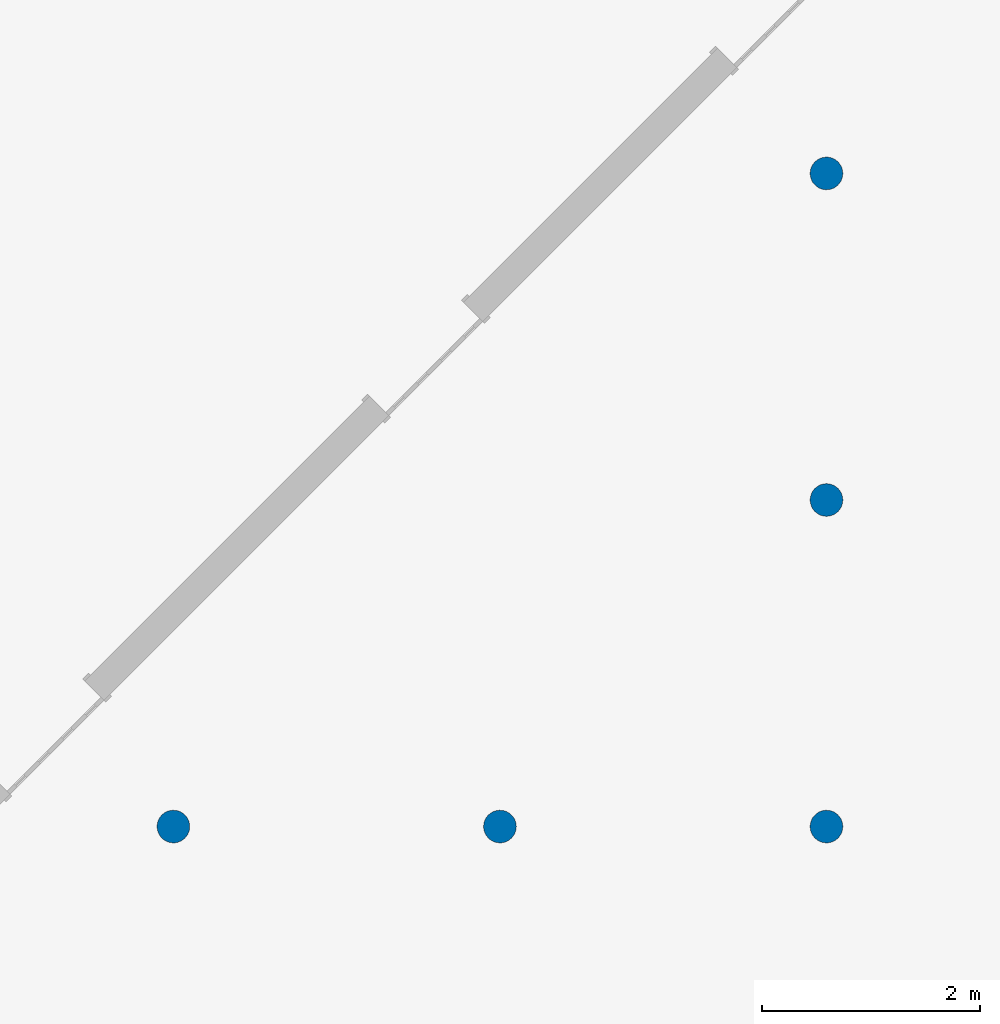
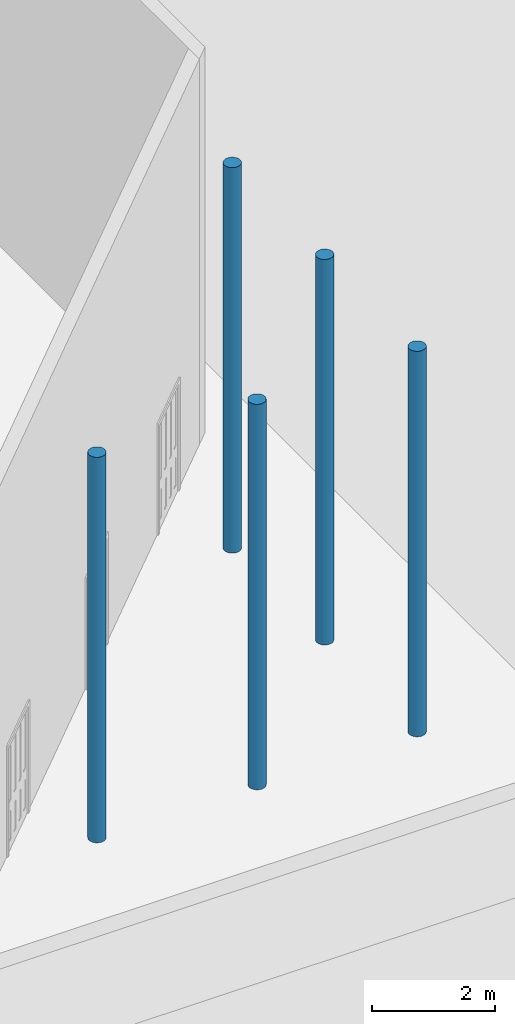
# One storey, part 4 of 39: 5 columns.
"""IFC2X3 building model written with IfcOpenShell, lengths in millimetres."""

from ifc_helpers import new_model, entity, si_unit, converted_unit, derived_unit, direction, frame, frame_2d, origin, place, context, subcontext, project, spatial, circle, extrude, source, transform, mapped, material, type_object, type_shapes, element, save


model = new_model("IFC2X3")

# Units and contexts
model_context = context("Model", 3, precision=1e-06, world=origin(), true_north=direction((2.0, 6.12303176911189e-17, 1.0)))
context_of_model = context(None, 3, precision=1e-06, world=origin(), true_north=direction((2.0, 6.12303176911189e-17, 1.0)))
body_context = subcontext(model_context, "Body", "Model", "MODEL_VIEW")
ifc_project = project(units=[si_unit("LENGTHUNIT", "METRE", prefix="MILLI"), si_unit("AREAUNIT", "SQUARE_METRE", prefix="MILLI"), si_unit("VOLUMEUNIT", "CUBIC_METRE", prefix="MILLI"), converted_unit("PLANEANGLEUNIT", "DEGREE", entity("IfcRatioMeasure", 0.0174532925199433), si_unit("PLANEANGLEUNIT", "RADIAN"), dimensions=[0, 0, 0, 0, 0, 0, 0]), si_unit("MASSUNIT", "GRAM", prefix="KILO"), si_unit("TIMEUNIT", "SECOND"), si_unit("THERMODYNAMICTEMPERATUREUNIT", "KELVIN"), derived_unit("THERMALTRANSMITTANCEUNIT", [(si_unit("MASSUNIT", "GRAM", prefix="KILO"), 1), (si_unit("THERMODYNAMICTEMPERATUREUNIT", "KELVIN"), -1), (si_unit("TIMEUNIT", "SECOND"), -3)]), derived_unit("VOLUMETRICFLOWRATEUNIT", [(si_unit("LENGTHUNIT", "METRE"), 3), (si_unit("TIMEUNIT", "SECOND"), -1)])], contexts=[model_context, context_of_model])

# Site, building, storey
site_placement = place(None, origin())
site = spatial("IfcSite", under=ifc_project, at=site_placement, CompositionType="ELEMENT")
building_placement = place(site_placement, origin())
building = spatial("IfcBuilding", under=site, at=building_placement, CompositionType="ELEMENT")
storey_placement = place(building_placement, frame((0.0, 0.0, 4000.0)))
storey = spatial("IfcBuildingStorey", under=building, at=storey_placement, Name="Level 2", CompositionType="ELEMENT", Elevation=4000.0)

# Columns
ifc_material = material(Name="Concrete - Cast-in-Place Concrete")
column_type_1 = type_object("IfcColumnType", Name="300mm", PredefinedType="COLUMN", material=ifc_material)
shared_shape_1 = source(origin(), body_context, "Body", "SweptSolid", [
    extrude(circle(Radius=149.999999999996, at=frame_2d((-49879.5139476853, 706004.002622383), x_axis=(1.0, 0.0))), origin(), (0.0, 0.0, 1.0), 7638.0),
])
type_shapes(column_type_1, [shared_shape_1])
column_1_placement = place(storey_placement, frame((0.0, 0.0, 362.0)))
element("IfcColumn", 1, at=column_1_placement, inside=storey, type_object=column_type_1, material=ifc_material, Name="M_Concrete-Round-Column:300mm", ObjectType="300mm", context=body_context, shape_type="MappedRepresentation", body=[
    mapped(shared_shape_1, transform((0.0, 0.0, 0.0), scale=1.0)),
])
column_type_2 = type_object("IfcColumnType", Name="300mm", PredefinedType="COLUMN", material=ifc_material)
shared_shape_2 = source(origin(), body_context, "Body", "SweptSolid", [
    extrude(circle(Radius=149.999999999996, at=frame_2d((-52879.5139476853, 706004.002622383), x_axis=(1.0, 0.0))), origin(), (0.0, 0.0, 1.0), 7638.0),
])
type_shapes(column_type_2, [shared_shape_2])
column_2_placement = place(storey_placement, frame((0.0, 0.0, 362.0)))
element("IfcColumn", 2, at=column_2_placement, inside=storey, type_object=column_type_2, material=ifc_material, Name="M_Concrete-Round-Column:300mm", ObjectType="300mm", context=body_context, shape_type="MappedRepresentation", body=[
    mapped(shared_shape_2, transform((0.0, 0.0, 0.0), scale=1.0)),
])
column_type_3 = type_object("IfcColumnType", Name="300mm", PredefinedType="COLUMN", material=ifc_material)
shared_shape_3 = source(origin(), body_context, "Body", "SweptSolid", [
    extrude(circle(Radius=149.999999999996, at=frame_2d((-55879.5139476853, 706004.002622383), x_axis=(1.0, 0.0))), origin(), (0.0, 0.0, 1.0), 7638.0),
])
type_shapes(column_type_3, [shared_shape_3])
column_3_placement = place(storey_placement, frame((0.0, 0.0, 362.0)))
element("IfcColumn", 3, at=column_3_placement, inside=storey, type_object=column_type_3, material=ifc_material, Name="M_Concrete-Round-Column:300mm", ObjectType="300mm", context=body_context, shape_type="MappedRepresentation", body=[
    mapped(shared_shape_3, transform((0.0, 0.0, 0.0), scale=1.0)),
])
column_type_4 = type_object("IfcColumnType", Name="300mm", PredefinedType="COLUMN", material=ifc_material)
shared_shape_4 = source(origin(), body_context, "Body", "SweptSolid", [
    extrude(circle(Radius=149.999999999996, at=frame_2d((-49879.5139476853, 709004.002622383), x_axis=(1.0, 0.0))), origin(), (0.0, 0.0, 1.0), 7638.0),
])
type_shapes(column_type_4, [shared_shape_4])
column_4_placement = place(storey_placement, frame((0.0, 0.0, 362.0)))
element("IfcColumn", 4, at=column_4_placement, inside=storey, type_object=column_type_4, material=ifc_material, Name="M_Concrete-Round-Column:300mm", ObjectType="300mm", context=body_context, shape_type="MappedRepresentation", body=[
    mapped(shared_shape_4, transform((0.0, 0.0, 0.0), scale=1.0)),
])
column_type_5 = type_object("IfcColumnType", Name="300mm", PredefinedType="COLUMN", material=ifc_material)
shared_shape_5 = source(origin(), body_context, "Body", "SweptSolid", [
    extrude(circle(Radius=149.999999999996, at=frame_2d((-49879.5139476853, 712004.002622383), x_axis=(1.0, 0.0))), origin(), (0.0, 0.0, 1.0), 7638.0),
])
type_shapes(column_type_5, [shared_shape_5])
column_5_placement = place(storey_placement, frame((0.0, 0.0, 362.0)))
element("IfcColumn", 5, at=column_5_placement, inside=storey, type_object=column_type_5, material=ifc_material, Name="M_Concrete-Round-Column:300mm", ObjectType="300mm", context=body_context, shape_type="MappedRepresentation", body=[
    mapped(shared_shape_5, transform((0.0, 0.0, 0.0), scale=1.0)),
])

save(model, "model.ifc")
